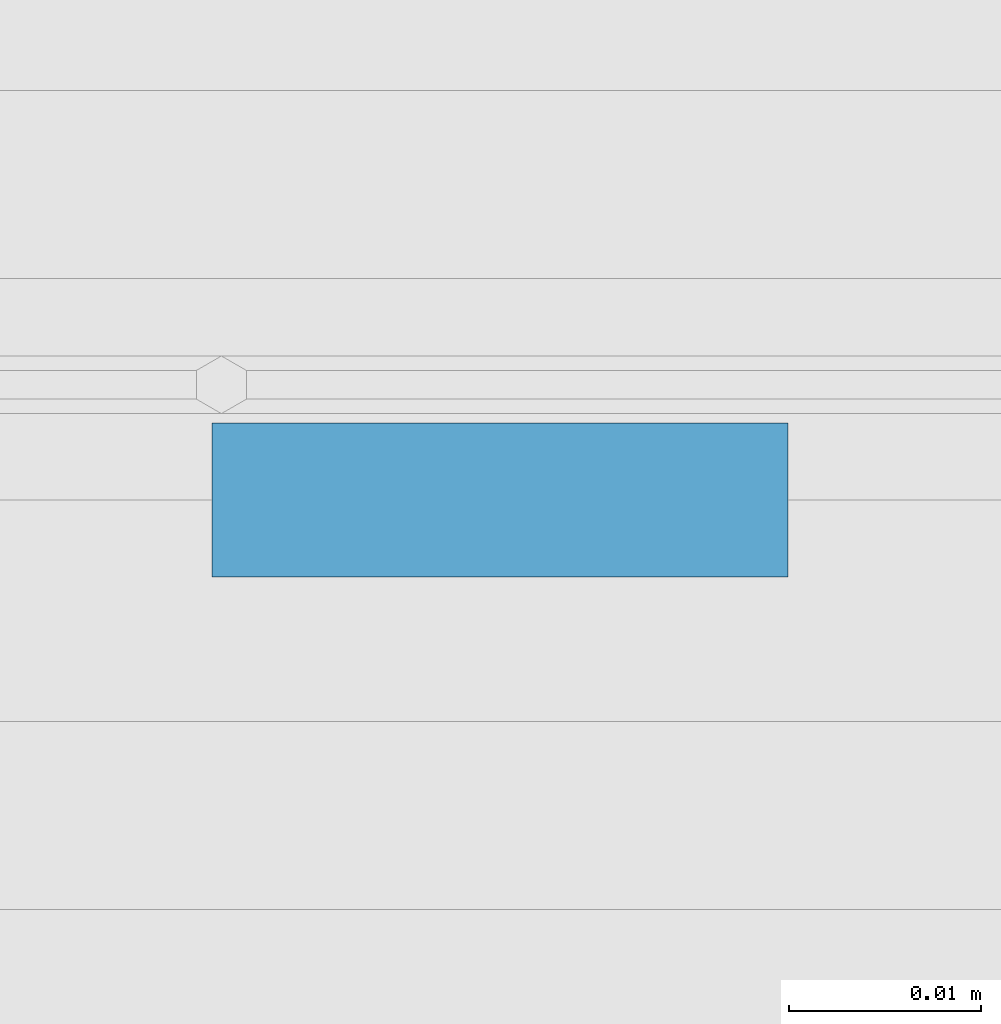
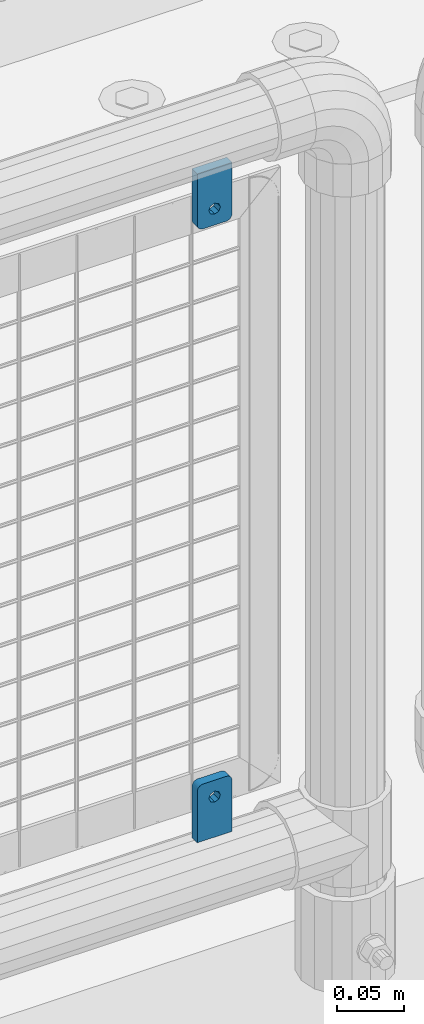
# One storey, part 242 of 247: 2 plates.
"""IFC2X3 building model written with IfcOpenShell, lengths in millimetres."""

from ifc_helpers import new_model, si_unit, frame, origin_with_axes, place, context, subcontext, project, spatial, faceted_brep, material, type_object, element, save


model = new_model("IFC2X3")

# Units and contexts
model_context = context("Model", 3, precision=1e-05, world=origin_with_axes())
body_context = subcontext(model_context, "Body", "Model", "MODEL_VIEW")
ifc_project = project(units=[si_unit("LENGTHUNIT", "METRE", prefix="MILLI"), si_unit("AREAUNIT", "SQUARE_METRE"), si_unit("VOLUMEUNIT", "CUBIC_METRE"), si_unit("MASSUNIT", "GRAM", prefix="KILO"), si_unit("TIMEUNIT", "SECOND"), si_unit("PLANEANGLEUNIT", "RADIAN"), si_unit("SOLIDANGLEUNIT", "STERADIAN"), si_unit("THERMODYNAMICTEMPERATUREUNIT", "DEGREE_CELSIUS"), si_unit("LUMINOUSINTENSITYUNIT", "LUMEN")], contexts=[model_context])

# Site, building, storey
site_placement = place(None, origin_with_axes())
site = spatial("IfcSite", under=ifc_project, at=site_placement, CompositionType="ELEMENT")
building_placement = place(site_placement, origin_with_axes())
building = spatial("IfcBuilding", under=site, at=building_placement, Name="Standard", CompositionType="ELEMENT")
storey_placement = place(building_placement, origin_with_axes())
storey = spatial("IfcBuildingStorey", under=building, at=storey_placement, Name="Undefined", CompositionType="ELEMENT", Elevation=0.0)

# Plates
ifc_material = material(Name="STEEL/S355J2")
plate_type = type_object("IfcPlateType", PredefinedType="NOTDEFINED")
plate_1_placement = place(storey_placement, frame((14920.85, 7664.49994161967, 328.320000000083), z_axis=(-1.0, 0.0, 0.0), x_axis=(0.0, 0.0, 1.0)))
element("IfcPlate", 1, at=plate_1_placement, inside=storey, type_object=plate_type, material=ifc_material, context=body_context, shape_type="Brep", body=[
    faceted_brep([(40.5355339059328, 4.00000000000091, 11.4644660900035), (40.5355339059328, -4.0, 11.4644660980035), (42.0, -4.0, 15.0000000039363), (42.0, 4.00000000000091, 14.9999999959363), (40.5355339059328, -4.0, 18.5355339098691), (40.5355339059328, 4.00000000000091, 18.535533901869), (37.0, -4.0, 20.0000000039363), (37.0, 4.00000000000091, 19.9999999959363), (33.4644660940672, -4.0, 18.5355339098691), (33.4644660940672, 4.00000000000091, 18.535533901869), (32.0, -4.0, 15.0000000039363), (32.0, 4.00000000000091, 14.9999999959363), (33.4644660940672, -4.0, 11.4644660980035), (33.4644660940672, 4.00000000000091, 11.4644660900035), (37.0, -4.0, 10.0000000039363), (37.0, 4.00000000000091, 9.99999999593626), (0.0, -3.99999999999909, 30.0), (47.0, -3.99999999999909, 30.0), (47.0, 4.00000000000091, 29.9999999999999), (0.0, 4.00000000000091, 29.9999999999999), (48.5450849718748, -3.99999999999909, 29.7552825814757), (48.5450849718748, 4.00000000000091, 29.7552825814757), (49.9389262614624, -3.99999999999909, 29.0450849718746), (49.9389262614624, 4.00000000000091, 29.0450849718746), (51.0450849718748, -4.0, 27.9389262614624), (51.0450849718748, 4.0, 27.9389262614623), (51.7552825814757, -4.0, 26.5450849718746), (51.7552825814757, 4.0, 26.5450849718746), (52.0, -4.0, 25.0), (52.0, 4.0, 24.9999999999999), (52.0, -4.0, 5.0), (52.0, 4.0, 4.99999999999989), (51.7552825814757, -4.0, 3.45491502812524), (51.7552825814757, 4.0, 3.45491502812524), (51.0450849718748, -4.0, 2.06107373853763), (51.0450849718748, 4.0, 2.06107373853752), (49.9389262614624, -4.0, 0.954915028125242), (49.9389262614624, 4.0, 0.954915028125242), (48.5450849718748, -4.0, 0.244717418524147), (48.5450849718748, 4.0, 0.244717418524147), (47.0, -4.0, 0.0), (47.0, 4.0, -1.13686837721616e-13), (0.0, -4.0, 0.0), (0.0, 4.0, -1.13686837721616e-13)], [[[0, 1, 2, 3]], [[3, 2, 4, 5]], [[5, 4, 6, 7]], [[7, 6, 8, 9]], [[9, 8, 10, 11]], [[11, 10, 12, 13]], [[13, 12, 14, 15]], [[15, 14, 1, 0]], [[16, 17, 18, 19]], [[17, 20, 21, 18]], [[20, 22, 23, 21]], [[22, 24, 25, 23]], [[24, 26, 27, 25]], [[26, 28, 29, 27]], [[28, 30, 31, 29]], [[30, 32, 33, 31]], [[32, 34, 35, 33]], [[34, 36, 37, 35]], [[36, 38, 39, 37]], [[38, 40, 41, 39]], [[40, 42, 43, 41]], [[18, 21, 23, 25, 27, 29, 31, 33, 35, 37, 39, 41, 43, 19], [11, 13, 15, 0, 3, 5, 7, 9]], [[42, 16, 19, 43]], [[40, 38, 36, 34, 32, 30, 28, 26, 24, 22, 20, 17, 16, 42], [2, 1, 14, 12, 10, 8, 6, 4]]]),
])
plate_2_placement = place(storey_placement, frame((14890.85, 7664.49994161967, 939.69999999993), z_axis=(1.0, 0.0, 0.0), x_axis=(0.0, 0.0, -1.0)))
element("IfcPlate", 2, at=plate_2_placement, inside=storey, type_object=plate_type, material=ifc_material, context=body_context, shape_type="Brep", body=[
    faceted_brep([(33.4644660940672, 4.00000000000091, 18.535533901869), (33.4644660940672, -4.0, 18.5355339098691), (32.0, -4.0, 15.0000000039363), (32.0, 4.00000000000091, 14.9999999959363), (33.4644660940672, -4.0, 11.4644660980035), (33.4644660940672, 4.00000000000091, 11.4644660900035), (37.0, -4.0, 10.0000000039363), (37.0, 4.00000000000091, 9.99999999593626), (40.5355339059328, -4.0, 11.4644660980035), (40.5355339059328, 4.00000000000091, 11.4644660900035), (42.0, -4.0, 15.0000000039363), (42.0, 4.00000000000091, 14.9999999959363), (40.5355339059328, -4.0, 18.5355339098691), (40.5355339059328, 4.00000000000091, 18.535533901869), (37.0, -4.0, 20.0000000039363), (37.0, 4.00000000000091, 19.9999999959363), (0.0, -3.99999999999909, 30.0), (47.0, -3.99999999999909, 30.0), (47.0, 4.00000000000091, 29.9999999999999), (0.0, 4.00000000000091, 29.9999999999999), (48.5450849718748, -3.99999999999909, 29.7552825814757), (48.5450849718748, 4.00000000000091, 29.7552825814757), (49.9389262614624, -3.99999999999909, 29.0450849718746), (49.9389262614624, 4.00000000000091, 29.0450849718746), (51.0450849718748, -4.0, 27.9389262614624), (51.0450849718748, 4.0, 27.9389262614623), (51.7552825814757, -4.0, 26.5450849718746), (51.7552825814757, 4.0, 26.5450849718746), (52.0, -4.0, 25.0), (52.0, 4.0, 24.9999999999999), (52.0, -4.0, 5.0), (52.0, 4.0, 4.99999999999989), (51.7552825814757, -4.0, 3.45491502812524), (51.7552825814757, 4.0, 3.45491502812524), (51.0450849718748, -4.0, 2.06107373853763), (51.0450849718748, 4.0, 2.06107373853752), (49.9389262614624, -4.0, 0.954915028125242), (49.9389262614624, 4.0, 0.954915028125242), (48.5450849718748, -4.0, 0.244717418524147), (48.5450849718748, 4.0, 0.244717418524147), (47.0, -4.0, 0.0), (47.0, 4.0, -1.13686837721616e-13), (0.0, -4.0, 0.0), (0.0, 4.0, -1.13686837721616e-13)], [[[0, 1, 2, 3]], [[3, 2, 4, 5]], [[5, 4, 6, 7]], [[7, 6, 8, 9]], [[9, 8, 10, 11]], [[11, 10, 12, 13]], [[13, 12, 14, 15]], [[15, 14, 1, 0]], [[16, 17, 18, 19]], [[17, 20, 21, 18]], [[20, 22, 23, 21]], [[22, 24, 25, 23]], [[24, 26, 27, 25]], [[26, 28, 29, 27]], [[28, 30, 31, 29]], [[30, 32, 33, 31]], [[32, 34, 35, 33]], [[34, 36, 37, 35]], [[36, 38, 39, 37]], [[38, 40, 41, 39]], [[40, 42, 43, 41]], [[18, 21, 23, 25, 27, 29, 31, 33, 35, 37, 39, 41, 43, 19], [3, 5, 7, 9, 11, 13, 15, 0]], [[42, 16, 19, 43]], [[40, 38, 36, 34, 32, 30, 28, 26, 24, 22, 20, 17, 16, 42], [10, 8, 6, 4, 2, 1, 14, 12]]]),
])

save(model, "model.ifc")
